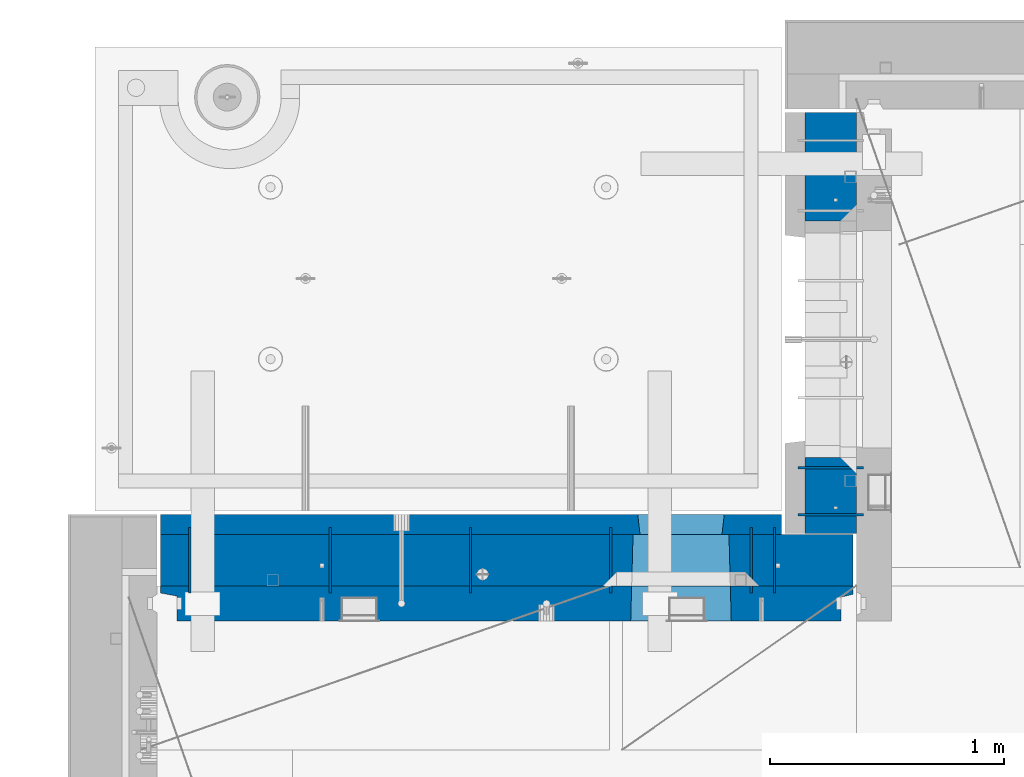
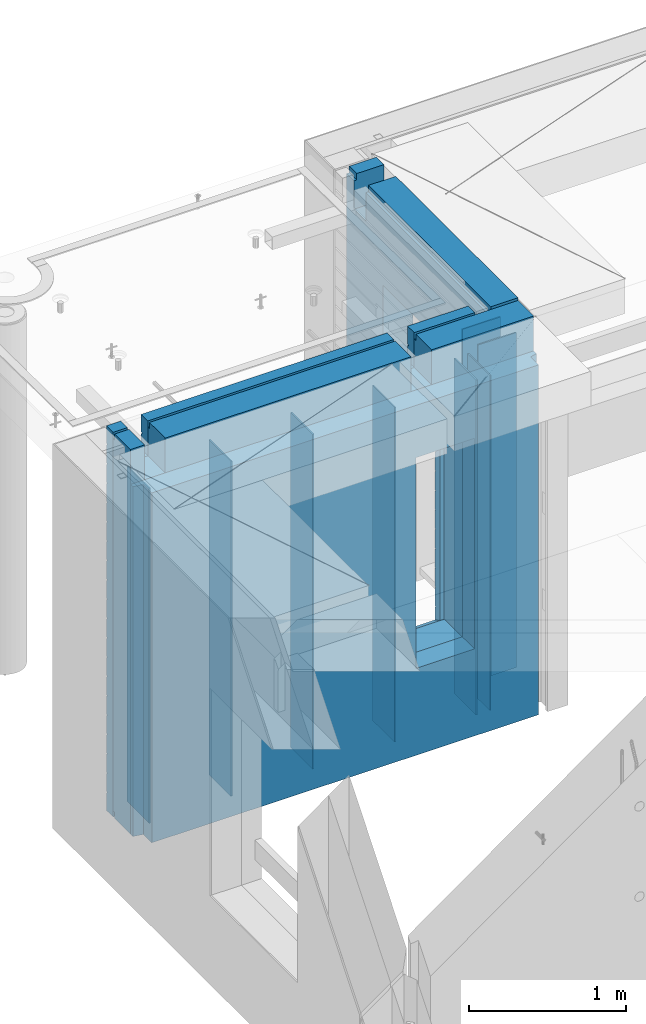
# One storey, part 235 of 349: 12 walls, 2 elements without a shape of their own.
"""IFC2X3 building model written with IfcOpenShell, lengths in millimetres."""

from ifc_helpers import new_model, si_unit, frame, origin_with_axes, place, context, subcontext, project, spatial, faceted_brep, material, type_object, element, aggregate, save


model = new_model("IFC2X3")

# Units and contexts
model_context = context("Model", 3, precision=1e-05, world=origin_with_axes())
body_context = subcontext(model_context, "Body", "Model", "MODEL_VIEW")
ifc_project = project(units=[si_unit("LENGTHUNIT", "METRE", prefix="MILLI"), si_unit("AREAUNIT", "SQUARE_METRE"), si_unit("VOLUMEUNIT", "CUBIC_METRE"), si_unit("MASSUNIT", "GRAM", prefix="KILO"), si_unit("TIMEUNIT", "SECOND"), si_unit("PLANEANGLEUNIT", "RADIAN"), si_unit("SOLIDANGLEUNIT", "STERADIAN"), si_unit("THERMODYNAMICTEMPERATUREUNIT", "DEGREE_CELSIUS"), si_unit("LUMINOUSINTENSITYUNIT", "LUMEN")], contexts=[model_context])

# Site, building, storey
site_placement = place(None, origin_with_axes())
site = spatial("IfcSite", under=ifc_project, at=site_placement, CompositionType="ELEMENT")
building_placement = place(site_placement, origin_with_axes())
building = spatial("IfcBuilding", under=site, at=building_placement, CompositionType="ELEMENT")
storey_placement = place(building_placement, origin_with_axes())
storey = spatial("IfcBuildingStorey", under=building, at=storey_placement, Name="4", CompositionType="ELEMENT", Elevation=0.0)

# Assembly, wall
assembly_1_placement = place(storey_placement, origin_with_axes())
assembly_1 = element("IfcElementAssembly", 1, at=assembly_1_placement, inside=storey, AssemblyPlace="NOTDEFINED", PredefinedType="REINFORCEMENT_UNIT")
ifc_material_1 = material(Name="Undefined")
wall_type_1 = type_object("IfcWallType", PredefinedType="NOTDEFINED")
wall_1_placement = place(assembly_1_placement, frame((11020.0, 20885.0002441406, 92115.0), z_axis=(0.0, 0.0, 1.0), x_axis=(-1.0, 3.00000001838171e-08, 0.0)))
wall_1 = element("IfcWall", 2, at=wall_1_placement, type_object=wall_type_1, material=ifc_material_1, Name="(PD)", context=body_context, shape_type="Brep", body=[
    faceted_brep([(0.0, 5.0, -1300.0), (0.0, 5.0, 1300.0), (280.0, 5.0, 1300.0), (280.0, 5.0, -1300.0), (0.0, -5.0, 1300.0), (280.0, -5.0, 1300.0), (0.0, -5.0, -1300.0), (280.0, -5.0, -1300.0)], [[[0, 1, 2, 3]], [[1, 4, 5, 2]], [[4, 6, 7, 5]], [[6, 0, 3, 7]], [[5, 7, 3, 2]], [[6, 4, 1, 0]]]),
])

assembly_2_placement = place(storey_placement, origin_with_axes())
assembly_2 = element("IfcElementAssembly", 3, at=assembly_2_placement, inside=storey, AssemblyPlace="NOTDEFINED", PredefinedType="REINFORCEMENT_UNIT")
wall_2_placement = place(assembly_2_placement, frame((10640.0002441406, 20549.9951872276, 92115.0), z_axis=(0.0, 0.0, 1.0), x_axis=(0.0, 1.0, 0.0)))
wall_2 = element("IfcWall", 4, at=wall_2_placement, type_object=wall_type_1, material=ifc_material_1, Name="(PD)", context=body_context, shape_type="Brep", body=[
    faceted_brep([(0.0, 5.0, -1300.0), (0.0, 5.0, 1300.0), (280.0, 5.0, 1300.0), (280.0, 5.0, -1300.0), (0.0, -5.0, 1300.0), (280.0, -5.0, 1300.0), (0.0, -5.0, -1300.0), (280.0, -5.0, -1300.0)], [[[0, 1, 2, 3]], [[1, 4, 5, 2]], [[4, 6, 7, 5]], [[6, 0, 3, 7]], [[5, 7, 3, 2]], [[6, 4, 1, 0]]]),
])

# Wall
wall_3_placement = place(assembly_1_placement, frame((11020.0, 21085.0002441406, 92115.0), z_axis=(0.0, 0.0, 1.0), x_axis=(-1.0, 3.00000001838171e-08, 0.0)))
wall_3 = element("IfcWall", 5, at=wall_3_placement, type_object=wall_type_1, material=ifc_material_1, Name="(PD)", context=body_context, shape_type="Brep", body=[
    faceted_brep([(0.0, 5.0, -1300.0), (0.0, 5.0, 1300.0), (280.0, 5.0, 1300.0), (280.0, 5.0, -1300.0), (0.0, -5.0, 1300.0), (280.0, -5.0, 1300.0), (0.0, -5.0, -1300.0), (280.0, -5.0, -1300.0)], [[[0, 1, 2, 3]], [[1, 4, 5, 2]], [[4, 6, 7, 5]], [[6, 0, 3, 7]], [[5, 7, 3, 2]], [[6, 4, 1, 0]]]),
])

wall_4_placement = place(assembly_2_placement, frame((8140.00024414063, 20549.9951872276, 92115.0), z_axis=(0.0, 0.0, 1.0), x_axis=(0.0, 1.0, 0.0)))
wall_4 = element("IfcWall", 6, at=wall_4_placement, type_object=wall_type_1, material=ifc_material_1, Name="(PD)", context=body_context, shape_type="Brep", body=[
    faceted_brep([(0.0, 5.0, -1300.0), (0.0, 5.0, 1300.0), (280.0, 5.0, 1300.0), (280.0, 5.0, -1300.0), (0.0, -5.0, 1300.0), (280.0, -5.0, 1300.0), (0.0, -5.0, -1300.0), (280.0, -5.0, -1300.0)], [[[0, 1, 2, 3]], [[1, 4, 5, 2]], [[4, 6, 7, 5]], [[6, 0, 3, 7]], [[5, 7, 3, 2]], [[6, 4, 1, 0]]]),
])

wall_5_placement = place(assembly_2_placement, frame((8740.00024414063, 20549.9951872276, 92115.0), z_axis=(0.0, 0.0, 1.0), x_axis=(0.0, 1.0, 0.0)))
wall_5 = element("IfcWall", 7, at=wall_5_placement, type_object=wall_type_1, material=ifc_material_1, Name="(PD)", context=body_context, shape_type="Brep", body=[
    faceted_brep([(0.0, 5.0, -1300.0), (0.0, 5.0, 1300.0), (280.0, 5.0, 1300.0), (280.0, 5.0, -1300.0), (0.0, -5.0, 1300.0), (280.0, -5.0, 1300.0), (0.0, -5.0, -1300.0), (280.0, -5.0, -1300.0)], [[[0, 1, 2, 3]], [[1, 4, 5, 2]], [[4, 6, 7, 5]], [[6, 0, 3, 7]], [[5, 7, 3, 2]], [[6, 4, 1, 0]]]),
])

wall_6_placement = place(assembly_2_placement, frame((9340.00024414063, 20549.9951872276, 92115.0), z_axis=(0.0, 0.0, 1.0), x_axis=(0.0, 1.0, 0.0)))
wall_6 = element("IfcWall", 8, at=wall_6_placement, type_object=wall_type_1, material=ifc_material_1, Name="(PD)", context=body_context, shape_type="Brep", body=[
    faceted_brep([(0.0, 5.0, -1300.0), (0.0, 5.0, 1300.0), (280.0, 5.0, 1300.0), (280.0, 5.0, -1300.0), (0.0, -5.0, 1300.0), (280.0, -5.0, 1300.0), (0.0, -5.0, -1300.0), (280.0, -5.0, -1300.0)], [[[0, 1, 2, 3]], [[1, 4, 5, 2]], [[4, 6, 7, 5]], [[6, 0, 3, 7]], [[5, 7, 3, 2]], [[6, 4, 1, 0]]]),
])

wall_7_placement = place(assembly_2_placement, frame((9940.00024414063, 20549.9951872276, 92115.0), z_axis=(0.0, 0.0, 1.0), x_axis=(0.0, 1.0, 0.0)))
wall_7 = element("IfcWall", 9, at=wall_7_placement, type_object=wall_type_1, material=ifc_material_1, Name="(PD)", context=body_context, shape_type="Brep", body=[
    faceted_brep([(0.0, 5.0, -1300.0), (0.0, 5.0, 1300.0), (280.0, 5.0, 1300.0), (280.0, 5.0, -1300.0), (0.0, -5.0, 1300.0), (280.0, -5.0, 1300.0), (0.0, -5.0, -1300.0), (280.0, -5.0, -1300.0)], [[[0, 1, 2, 3]], [[1, 4, 5, 2]], [[4, 6, 7, 5]], [[6, 0, 3, 7]], [[5, 7, 3, 2]], [[6, 4, 1, 0]]]),
])

wall_8_placement = place(assembly_2_placement, frame((10540.0002441406, 20549.9951872276, 92115.0), z_axis=(0.0, 0.0, 1.0), x_axis=(0.0, 1.0, 0.0)))
wall_8 = element("IfcWall", 10, at=wall_8_placement, type_object=wall_type_1, material=ifc_material_1, Name="(PD)", context=body_context, shape_type="Brep", body=[
    faceted_brep([(0.0, 5.0, -1300.0), (0.0, 5.0, 1300.0), (280.0, 5.0, 1300.0), (280.0, 5.0, -1300.0), (0.0, -5.0, 1300.0), (280.0, -5.0, 1300.0), (0.0, -5.0, -1300.0), (280.0, -5.0, -1300.0)], [[[0, 1, 2, 3]], [[1, 4, 5, 2]], [[4, 6, 7, 5]], [[6, 0, 3, 7]], [[5, 7, 3, 2]], [[6, 4, 1, 0]]]),
])

ifc_material_2 = material(Name="COS5gt")
wall_type_2 = type_object("IfcWallType", PredefinedType="NOTDEFINED")
wall_9_placement = place(assembly_1_placement, frame((10880.0, 20805.0, 92247.5), z_axis=(0.0, 0.0, 1.0), x_axis=(0.0, 1.0, 0.0)))
wall_9 = element("IfcWall", 11, at=wall_9_placement, type_object=wall_type_2, material=ifc_material_2, context=body_context, shape_type="Brep", body=[
    faceted_brep([(1800.0, -110.0, 1492.5), (1800.0, 90.0, 1492.5), (1705.0, 90.0, 1492.5), (1705.0, -110.0, 1492.5), (1800.0, 90.0, 1442.5), (1800.0, 110.0, 1442.5), (1705.0, 110.0, 1442.5), (1705.0, 90.0, 1442.5), (0.0, 110.0, 1442.5), (0.0, 90.0, 1442.5), (1555.0, 90.0, 1442.5), (1555.0, 110.0, 1442.5), (0.0, -110.0, -1492.5), (0.0, 90.0, -1492.5), (325.000271651108, 90.0, -1492.5), (325.000271651108, -110.0, -1492.5), (0.0, 90.0, -1442.5), (325.000271651108, 90.0, -1442.5), (0.0, -110.0, 1492.5), (0.0, 90.0, 1492.5), (0.0, 110.0, -1442.5), (325.000271651108, 110.0, -1442.5), (325.000271651108, 110.0, 857.5), (325.000271651108, -110.0, 857.5), (1335.00027165111, 110.0, 857.5), (1335.00027165111, -110.0, 857.5), (1555.0, 110.0, 1222.5), (1705.0, 110.0, 1222.5), (1800.0, 110.0, -1442.5), (1335.00027165111, 110.0, -1442.5), (1800.0, 90.0, -1442.5), (1800.0, 90.0, -1492.5), (1335.00027165111, 90.0, -1492.5), (1335.00027165111, 90.0, -1442.5), (1800.0, -110.0, -1492.5), (1335.00027165111, -110.0, -1492.5), (1705.0, -110.0, 1222.5), (1555.0, -110.0, 1222.5), (1555.0, -110.0, 1492.5), (1555.0, 90.0, 1492.5)], [[[0, 1, 2, 3]], [[4, 5, 6, 7]], [[8, 9, 10, 11]], [[12, 13, 14, 15]], [[13, 16, 17, 14]], [[13, 12, 18, 19, 9, 8, 20, 16]], [[16, 20, 21, 17]], [[15, 14, 17, 21, 22, 23]], [[23, 22, 24, 25]], [[21, 20, 8, 11, 26, 27, 6, 5, 28, 29, 24, 22]], [[30, 31, 32, 33]], [[28, 30, 33, 29]], [[5, 4, 1, 0, 34, 31, 30, 28]], [[31, 34, 35, 32]], [[25, 24, 29, 33, 32, 35]], [[34, 0, 3, 36, 37, 38, 18, 12, 15, 23, 25, 35]], [[19, 18, 38, 39]], [[9, 19, 39, 10]], [[38, 37, 26, 11, 10, 39]], [[36, 27, 26, 37]], [[3, 2, 7, 6, 27, 36]], [[1, 4, 7, 2]]]),
])

aggregate(assembly_1, [wall_1, wall_3, wall_9])

wall_10_placement = place(assembly_2_placement, frame((8000.0, 20689.9951872276, 92247.5), z_axis=(0.0, 0.0, 1.0), x_axis=(1.0, 0.0, 0.0)))
wall_10 = element("IfcWall", 12, at=wall_10_placement, type_object=wall_type_2, material=ifc_material_2, context=body_context, shape_type="Brep", body=[
    faceted_brep([(2075.0, 110.0, 1442.5), (2075.0, 90.0, 1442.5), (2075.0, 90.0, 1492.5), (2075.0, -110.0, 1492.5), (2075.0, -110.000000000004, 1222.5), (2075.0, 109.999999999996, 1222.5), (2225.0, -110.000000000004, 1222.5), (2225.0, 109.999999999996, 1222.5), (2225.0, 110.0, 1442.5), (2225.0, -110.0, 1492.5), (2225.0, 90.0, 1492.5), (2225.0, 90.0, 1442.5), (2975.0, 90.0, -1492.5), (15.0, 90.0, -1492.5), (15.0, 90.0, -1442.5), (2975.0, 90.0, -1442.5), (2975.0, -110.0, -1492.5), (15.0, -110.0, -1492.5), (15.0, 90.0, 1442.5), (15.0, 90.0, 1492.5), (119.999999999998, 90.0, 1492.5), (119.999999999998, 90.0, 1442.5), (15.0, -110.0, 1492.5), (119.999999999998, -110.0, 1492.5), (269.999999999998, 110.0, 1442.5), (269.999999999998, 90.0, 1442.5), (269.999999999998, 90.0, 1492.5), (269.999999999998, -110.0, 1492.5), (269.999999999998, 110.0, 1222.5), (269.999999999998, -110.0, 1222.5), (119.999999999998, 110.0, 1222.5), (119.999999999998, -110.0, 1222.5), (119.999999999998, 110.0, 1442.5), (15.0, 110.0, 1442.5), (15.0, 110.0, -1442.5), (2975.0, 110.0, -1442.5), (2975.0, 110.0, 1442.5), (2975.0, 90.0, 1442.5), (2975.0, 90.0, 1492.5), (2975.0, -110.0, 1492.5), (2029.05276420954, -110.0, -813.445945945947), (2029.05276420954, -110.0, 813.445945945947), (2450.94465610143, -110.0, 813.445945945947), (2450.94465610143, -110.0, -813.445945945947), (2034.99871015549, 110.0, -802.5), (2034.99871015549, 110.0, 807.5), (2034.99871015549, 110.0, -807.5), (2444.99871015549, 110.0, -807.5), (2414.99871015549, 110.0, -807.5), (2064.99871015549, 110.0, -807.5), (2444.99871015549, 110.0, 807.5), (2444.99871015549, 110.0, -802.5)], [[[0, 1, 2, 3, 4, 5]], [[5, 4, 6, 7]], [[8, 7, 6, 9, 10, 11]], [[12, 13, 14, 15]], [[16, 17, 13, 12]], [[18, 19, 20, 21]], [[19, 22, 23, 20]], [[24, 25, 1, 0]], [[26, 27, 3, 2]], [[25, 26, 2, 1]], [[24, 28, 29, 27, 26, 25]], [[30, 31, 29, 28]], [[32, 21, 20, 23, 31, 30]], [[33, 18, 21, 32]], [[13, 17, 22, 19, 18, 33, 34, 14]], [[35, 15, 14, 34]], [[36, 37, 38, 39, 16, 12, 15, 35]], [[37, 36, 8, 11]], [[38, 37, 11, 10]], [[39, 38, 10, 9]], [[4, 3, 27, 29, 31, 23, 22, 17, 16, 39, 9, 6], [40, 41, 42, 43]], [[44, 45, 41, 40, 46]], [[43, 47, 48, 49, 46, 40]], [[42, 50, 51, 47, 43]], [[41, 45, 50, 42]], [[36, 35, 34, 33, 32, 30, 28, 24, 0, 5, 7, 8], [44, 46, 49, 48, 47, 51, 50, 45]]]),
])

ifc_material_3 = material(Name="CONCRETE/C30/37")
wall_type_3 = type_object("IfcWallType", PredefinedType="NOTDEFINED")
wall_11_placement = place(assembly_2_placement, frame((8000.0, 20842.4951872276, 92247.5), z_axis=(0.0, 0.0, 1.0), x_axis=(1.0, 0.0, 0.0)))
wall_11 = element("IfcWall", 13, at=wall_11_placement, type_object=wall_type_3, material=ifc_material_3, context=body_context, shape_type="Brep", body=[
    faceted_brep([(2075.0, 42.5, 1492.5), (2075.0, -42.5, 1492.5), (2075.0, -42.5000000000036, 1222.5), (2075.0, 42.4999994593163, 1222.5), (2075.0, 42.4999996925035, 1342.99999994476), (2075.0, 32.4999992506928, 1344.9999999992), (2075.0, 32.4999991126933, 1355.00000040043), (2075.0, 42.4999994127757, 1356.99999988925), (2225.0, -42.5000000000036, 1222.5), (2225.0, 42.4999994264763, 1222.5), (2225.0, 42.5, 1492.5), (2225.0, 42.4999993700148, 1356.99999988925), (2225.0, 32.4999991126933, 1355.00000040043), (2225.0, 32.4999992506928, 1344.9999999992), (2225.0, 42.4999996701117, 1342.99999994476), (2225.0, -42.5, 1492.5), (2054.99871015549, 42.5, -857.5), (2064.99871015549, -42.5, -807.5), (2414.99871015549, -42.5, -807.5), (2424.99871015549, 42.5, -857.5), (15.0, 42.5, -757.000000055239), (15.0, 32.4999992506928, -755.0000000008), (2056.17518083188, 32.4999992506928, -755.0000000008), (2054.99871015549, 42.4999994516256, -757.000000055239), (15.0, 32.4999991126933, -744.999999599575), (2056.17518084811, 32.4999991126933, -744.999999599575), (15.0, 42.5, -743.000000110755), (2054.99871015549, 42.4999994184764, -743.000000110755), (15.0, 42.5, -607.000000055239), (2054.99871015549, 42.4999994538521, -607.000000055239), (15.0, 32.4999992506928, -605.0000000008), (2056.17518083188, 32.4999992506928, -605.0000000008), (15.0, 32.4999991126933, -594.999999599575), (2056.17518084811, 32.4999991126933, -594.999999599575), (15.0, 42.5, -593.000000110755), (2054.99871015549, 42.4999994184764, -593.000000110755), (15.0, 42.5, -457.000000055239), (2054.99871015549, 42.4999994563987, -457.000000055239), (15.0000000000009, 32.4999992506928, -455.0000000008), (2056.17518083188, 32.4999992506928, -455.0000000008), (15.0000000000009, 32.4999991126933, -444.999999599575), (2056.17518084811, 32.4999991126933, -444.999999599575), (15.0, 42.5, -443.000000110755), (2054.99871015549, 42.4999994184764, -443.000000110755), (15.0, 42.5, -307.000000055239), (2054.99871015549, 42.4999994593381, -307.000000055239), (15.0, 32.4999992506928, -305.0000000008), (2056.17518083188, 32.4999992506928, -305.0000000008), (15.0, 32.4999991126933, -294.999999599575), (2056.17518084811, 32.4999991126933, -294.999999599575), (15.0, 42.5, -293.000000110755), (2054.99871015549, 42.4999994184764, -293.000000110755), (15.0, 42.5, -157.000000055239), (2054.99871015549, 42.4999994627688, -157.000000055239), (15.0000000000009, 32.4999992506928, -155.0000000008), (2056.17518083188, 32.4999992506928, -155.0000000008), (15.0000000000009, 32.4999991126933, -144.999999599575), (2056.17518084811, 32.4999991126933, -144.999999599575), (15.0, 42.5, -143.000000110755), (2054.99871015549, 42.4999994184764, -143.000000110755), (15.0, 42.5, -7.00000005523907), (2054.99871015549, 42.4999994668287, -7.00000005523907), (14.9999999999991, 32.4999992506928, -5.00000000080036), (2056.17518083188, 32.4999992506928, -5.00000000080036), (14.9999999999991, 32.4999991126933, 5.00000040042505), (2056.17518084811, 32.4999991126933, 5.00000040042505), (15.0, 42.5, 6.99999988924537), (2054.99871015549, 42.4999994184764, 6.99999988924537), (15.0, 42.5, 142.999999944761), (2054.99871015549, 42.4999994717145, 142.999999944761), (15.0000000000009, 32.4999992506928, 144.9999999992), (2056.17518083188, 32.4999992506928, 144.9999999992), (15.0000000000009, 32.4999991126933, 155.000000400425), (2056.17518084811, 32.4999991126933, 155.000000400425), (15.0, 42.5, 156.999999889245), (2054.99871015549, 42.4999994184764, 156.999999889245), (15.0, 42.5, 292.999999944761), (2054.99871015549, 42.4999994776954, 292.999999944761), (15.0, 32.4999992506928, 294.9999999992), (2056.17518083188, 32.4999992506928, 294.9999999992), (15.0, 32.4999991126933, 305.000000400425), (2056.17518084811, 32.4999991126933, 305.000000400425), (15.0, 42.5, 306.999999889245), (2054.99871015549, 42.4999994184764, 306.999999889245), (15.0, 42.5, 442.999999944761), (2054.99871015549, 42.499999485186, 442.999999944761), (15.0, 32.4999992506928, 444.9999999992), (2056.17518083188, 32.4999992506928, 444.9999999992), (15.0, 32.4999991126933, 455.000000400425), (2056.17518084811, 32.4999991126933, 455.000000400425), (15.0, 42.5, 456.999999889245), (2054.99871015549, 42.4999994184764, 456.999999889245), (15.0, 42.5, 592.999999944761), (2054.99871015549, 42.4999994948485, 592.999999944761), (15.0, 32.4999992506928, 594.9999999992), (2056.17518083188, 32.4999992506928, 594.9999999992), (15.0, 32.4999991126933, 605.000000400425), (2056.17518084811, 32.4999991126933, 605.000000400425), (15.0, 42.5, 606.999999889245), (2054.99871015549, 42.4999994184764, 606.999999889245), (15.0, 42.5, 742.999999944761), (2054.99871015549, 42.4999995077887, 742.999999944761), (15.0, 32.4999992506928, 744.9999999992), (2056.17518083188, 32.4999992506928, 744.9999999992), (15.0, 32.4999991126933, 755.000000400425), (2056.17518084811, 32.4999991126933, 755.000000400425), (15.0, 42.5, 756.999999889245), (2054.99871015549, 42.4999994184764, 756.999999889245), (2670.0, 32.4999992506928, 1194.9999999992), (15.0000000000009, 32.4999992506928, 1194.9999999992), (15.0000000000009, 32.4999991126933, 1205.00000040043), (2670.0, 32.4999991126933, 1205.00000040043), (2670.0, 42.4999994795107, 1192.99999994476), (15.0, 42.5, 1192.99999994476), (2670.0, 42.4999992431622, 1056.99999988925), (15.0, 42.5, 1056.99999988925), (2670.0, 32.4999991126933, 1055.00000040043), (15.0, 32.4999991126933, 1055.00000040043), (2670.0, 32.4999992506928, 1044.9999999992), (15.0, 32.4999992506928, 1044.9999999992), (2670.0, 42.4999994189602, 1042.99999994476), (15.0, 42.5, 1042.99999994476), (2670.0, 42.4999992431622, 906.999999889245), (15.0, 42.5, 906.999999889245), (2670.0, 32.4999991126933, 905.000000400425), (15.0, 32.4999991126933, 905.000000400425), (2670.0, 32.4999992506928, 894.9999999992), (15.0, 32.4999992506928, 894.9999999992), (2670.0, 42.4999993831079, 892.999999944761), (15.0, 42.5, 892.999999944761), (2670.0, 32.4999992506928, -755.0000000008), (2670.0, 42.4999992863086, -757.000000055239), (2424.99871015549, 42.4999993521669, -757.000000055239), (2423.8222394791, 32.4999992506928, -755.0000000008), (2670.0, 32.4999991126933, -744.999999599575), (2423.82223946286, 32.4999991126933, -744.999999599575), (2670.0, 42.4999992431622, -743.000000110755), (2424.99871015549, 42.4999993130041, -743.000000110755), (2670.0, 42.4999992892044, -607.000000055239), (2424.99871015549, 42.4999993547972, -607.000000055239), (2670.0, 32.4999992506928, -605.0000000008), (2423.8222394791, 32.4999992506928, -605.0000000008), (2670.0, 32.4999991126933, -594.999999599575), (2423.82223946286, 32.4999991126933, -594.999999599575), (2670.0, 42.4999992431622, -593.000000110755), (2424.99871015549, 42.4999993130041, -593.000000110755), (2670.0, 42.4999992925186, -457.000000055239), (2424.99871015549, 42.4999993578058, -457.000000055239), (2670.0, 32.4999992506928, -455.0000000008), (2423.8222394791, 32.4999992506928, -455.0000000008), (2670.0, 32.4999991126933, -444.999999599575), (2423.82223946286, 32.4999991126933, -444.999999599575), (2670.0, 42.4999992431622, -443.000000110755), (2424.99871015549, 42.4999993130041, -443.000000110755), (2670.0, 42.4999992963421, -307.000000055239), (2424.99871015549, 42.4999993612764, -307.000000055239), (2670.0, 32.4999992506928, -305.0000000008), (2423.8222394791, 32.4999992506928, -305.0000000008), (2670.0, 32.4999991126933, -294.999999599575), (2423.82223946286, 32.4999991126933, -294.999999599575), (2670.0, 42.4999992431622, -293.000000110755), (2424.99871015549, 42.4999993130041, -293.000000110755), (2670.0, 42.4999993008096, -157.000000055239), (2424.99871015549, 42.4999993653291, -157.000000055239), (2670.0, 32.4999992506928, -155.0000000008), (2423.8222394791, 32.4999992506928, -155.0000000008), (2670.0, 32.4999991126933, -144.999999599575), (2423.82223946286, 32.4999991126933, -144.999999599575), (2670.0, 42.4999992431622, -143.000000110755), (2424.99871015549, 42.4999993130041, -143.000000110755), (2670.0, 42.4999993060956, -7.00000005523907), (2424.99871015549, 42.4999993701276, -7.00000005523907), (2670.0, 32.4999992506928, -5.00000000080036), (2423.8222394791, 32.4999992506928, -5.00000000080036), (2670.0, 32.4999991126933, 5.00000040042505), (2423.82223946286, 32.4999991126933, 5.00000040042505), (2670.0, 42.4999992431622, 6.99999988924537), (2424.99871015549, 42.4999993130041, 6.99999988924537), (2670.0, 42.4999993124511, 142.999999944761), (2424.99871015549, 42.4999993758975, 142.999999944761), (2670.0, 32.4999992506928, 144.9999999992), (2423.8222394791, 32.4999992506928, 144.9999999992), (2670.0, 32.4999991126933, 155.000000400425), (2423.82223946286, 32.4999991126933, 155.000000400425), (2670.0, 42.4999992431622, 156.999999889245), (2424.99871015549, 42.4999993130041, 156.999999889245), (2670.0, 42.4999993202327, 292.999999944761), (2424.99871015549, 42.4999993829624, 292.999999944761), (2670.0, 32.4999992506928, 294.9999999992), (2423.8222394791, 32.4999992506928, 294.9999999992), (2670.0, 32.4999991126933, 305.000000400425), (2423.82223946286, 32.4999991126933, 305.000000400425), (2670.0, 42.4999992431622, 306.999999889245), (2424.99871015549, 42.4999993130041, 306.999999889245), (2670.0, 42.4999993299862, 442.999999944761), (2424.99871015549, 42.4999993918136, 442.999999944761), (2670.0, 32.4999992506928, 444.9999999992), (2423.8222394791, 32.4999992506928, 444.9999999992), (2670.0, 32.4999991126933, 455.000000400425), (2423.82223946286, 32.4999991126933, 455.000000400425), (2670.0, 42.4999992431622, 456.999999889245), (2424.99871015549, 42.4999993130041, 456.999999889245), (2670.0, 42.4999993425627, 592.999999944761), (2424.99871015549, 42.4999994032296, 592.999999944761), (2670.0, 32.4999992506928, 594.9999999992), (2423.8222394791, 32.4999992506928, 594.9999999992), (2670.0, 32.4999991126933, 605.000000400425), (2423.82223946286, 32.4999991126933, 605.000000400425), (2670.0, 42.4999992431622, 606.999999889245), (2424.99871015549, 42.4999993130041, 606.999999889245), (2670.0, 42.4999993594029, 742.999999944761), (2424.99871015549, 42.4999994185164, 742.999999944761), (2670.0, 32.4999992506928, 744.9999999992), (2423.8222394791, 32.4999992506928, 744.9999999992), (2670.0, 32.4999991126933, 755.000000400425), (2423.82223946286, 32.4999991126933, 755.000000400425), (2670.0, 42.4999992431622, 756.999999889245), (2424.99871015549, 42.4999993130041, 756.999999889245), (2064.99871015549, 42.5, 782.5), (2054.99871015549, 42.5, 782.5), (2424.99871015549, 42.5, 782.5), (2414.99871015549, 42.5, 782.5), (2064.99871015549, -42.5, 782.5), (2064.99871015549, -42.5, 787.5), (2414.99871015549, -42.5, 787.5), (2414.99871015549, -42.5, 782.5), (2670.0, 42.4999992431622, -893.000000110755), (15.0, 42.5, -893.000000110755), (2670.0, 32.4999991126933, -894.999999599575), (15.0000000000009, 32.4999991126933, -894.999999599575), (2670.0, 32.4999992506928, -905.0000000008), (15.0000000000009, 32.4999992506928, -905.0000000008), (2670.0, 42.4999992837584, -907.000000055239), (15.0, 42.5, -907.000000055239), (2670.0, 42.4999992431622, -1043.00000011075), (15.0, 42.5, -1043.00000011075), (2670.0, 32.4999991126933, -1044.99999959957), (15.0, 32.4999991126933, -1044.99999959957), (2670.0, 32.4999992506928, -1055.0000000008), (15.0, 32.4999992506928, -1055.0000000008), (2670.0, 42.4999992814919, -1057.00000005524), (15.0, 42.5, -1057.00000005524), (2670.0, 42.4999992431622, -1193.00000011075), (15.0, 42.5, -1193.00000011075), (2670.0, 32.4999991126933, -1194.99999959957), (15.0, 32.4999991126933, -1194.99999959957), (2670.0, 32.4999992506928, -1205.0000000008), (15.0, 32.4999992506928, -1205.0000000008), (2670.0, 42.4999992794619, -1207.00000005524), (15.0, 42.5, -1207.00000005524), (2670.0, 42.4999992431622, -1343.00000011075), (15.0, 42.5, -1343.00000011075), (2670.0, 32.4999991126933, -1344.99999959957), (15.0, 32.4999991126933, -1344.99999959957), (2670.0, 32.4999992506928, -1355.0000000008), (15.0, 32.4999992506928, -1355.0000000008), (2670.0, 42.5, -1357.00000005524), (15.0, 42.5, -1357.00000005524), (2670.0, 42.5, -1492.5), (15.0, 42.5, -1492.5), (15.0, -42.5, -1492.5), (2670.0, -42.5, -1492.5), (15.0, 42.5, 1356.99999988925), (15.0, 42.5, 1492.5), (119.999999999998, 42.5, 1492.5), (119.999999999998, 42.4999999700703, 1356.99999988925), (15.0, -42.5, 1492.5), (119.999999999998, -42.5, 1492.5), (269.999999999998, 42.5, 1492.5), (269.999999999998, 42.4999999273095, 1356.99999988925), (269.999999999998, 32.4999991126933, 1355.00000040043), (269.999999999998, 32.4999992506928, 1344.9999999992), (269.999999999998, 42.4999999619358, 1342.99999994476), (269.999999999998, 42.4999998750354, 1222.5), (269.999999999998, -42.5, 1222.5), (269.999999999998, -42.5, 1492.5), (119.999999999998, 42.4999999076099, 1222.5), (119.999999999998, -42.5, 1222.5), (15.0, 42.5, 1342.99999994476), (15.0, 32.4999992506928, 1344.9999999992), (119.999999999998, 32.4999992506928, 1344.9999999992), (119.999999999998, 42.4999999843276, 1342.99999994476), (15.0, 32.4999991126933, 1355.00000040043), (119.999999999998, 32.4999991126933, 1355.00000040043), (15.0, 42.5, 1206.99999988925), (2670.0, 42.4999992431622, 1206.99999988925), (2670.0, 42.5, 1492.5), (2670.0, -42.5, 1492.5), (2670.0, 42.4999996036859, 1342.99999994476), (2670.0, 32.4999992506928, 1344.9999999992), (2670.0, 32.4999991126933, 1355.00000040043), (2670.0, 42.4999992431622, 1356.99999988925)], [[[0, 1, 2, 3, 4, 5, 6, 7]], [[3, 2, 8, 9]], [[10, 11, 12, 13, 14, 9, 8, 15]], [[16, 17, 18, 19]], [[20, 21, 22, 23]], [[21, 24, 25, 22]], [[24, 26, 27, 25]], [[26, 28, 29, 27]], [[28, 30, 31, 29]], [[30, 32, 33, 31]], [[32, 34, 35, 33]], [[34, 36, 37, 35]], [[36, 38, 39, 37]], [[38, 40, 41, 39]], [[40, 42, 43, 41]], [[42, 44, 45, 43]], [[44, 46, 47, 45]], [[46, 48, 49, 47]], [[48, 50, 51, 49]], [[50, 52, 53, 51]], [[52, 54, 55, 53]], [[54, 56, 57, 55]], [[56, 58, 59, 57]], [[58, 60, 61, 59]], [[60, 62, 63, 61]], [[62, 64, 65, 63]], [[64, 66, 67, 65]], [[66, 68, 69, 67]], [[68, 70, 71, 69]], [[70, 72, 73, 71]], [[72, 74, 75, 73]], [[74, 76, 77, 75]], [[76, 78, 79, 77]], [[78, 80, 81, 79]], [[80, 82, 83, 81]], [[82, 84, 85, 83]], [[84, 86, 87, 85]], [[86, 88, 89, 87]], [[88, 90, 91, 89]], [[90, 92, 93, 91]], [[92, 94, 95, 93]], [[94, 96, 97, 95]], [[96, 98, 99, 97]], [[98, 100, 101, 99]], [[100, 102, 103, 101]], [[102, 104, 105, 103]], [[104, 106, 107, 105]], [[108, 109, 110, 111]], [[112, 113, 109, 108]], [[114, 115, 113, 112]], [[114, 116, 117, 115]], [[118, 119, 117, 116]], [[120, 121, 119, 118]], [[122, 123, 121, 120]], [[122, 124, 125, 123]], [[126, 127, 125, 124]], [[128, 129, 127, 126]], [[130, 131, 132, 133]], [[134, 130, 133, 135]], [[136, 134, 135, 137]], [[138, 136, 137, 139]], [[140, 138, 139, 141]], [[142, 140, 141, 143]], [[144, 142, 143, 145]], [[146, 144, 145, 147]], [[148, 146, 147, 149]], [[150, 148, 149, 151]], [[152, 150, 151, 153]], [[154, 152, 153, 155]], [[156, 154, 155, 157]], [[158, 156, 157, 159]], [[160, 158, 159, 161]], [[162, 160, 161, 163]], [[164, 162, 163, 165]], [[166, 164, 165, 167]], [[168, 166, 167, 169]], [[170, 168, 169, 171]], [[172, 170, 171, 173]], [[174, 172, 173, 175]], [[176, 174, 175, 177]], [[178, 176, 177, 179]], [[180, 178, 179, 181]], [[182, 180, 181, 183]], [[184, 182, 183, 185]], [[186, 184, 185, 187]], [[188, 186, 187, 189]], [[190, 188, 189, 191]], [[192, 190, 191, 193]], [[194, 192, 193, 195]], [[196, 194, 195, 197]], [[198, 196, 197, 199]], [[200, 198, 199, 201]], [[202, 200, 201, 203]], [[204, 202, 203, 205]], [[206, 204, 205, 207]], [[208, 206, 207, 209]], [[210, 208, 209, 211]], [[212, 210, 211, 213]], [[214, 212, 213, 215]], [[216, 214, 215, 217]], [[218, 219, 107, 106, 129, 128, 216, 217, 220, 221]], [[222, 17, 16, 23, 22, 25, 27, 29, 31, 33, 35, 37, 39, 41, 43, 45, 47, 49, 51, 53, 55, 57, 59, 61, 63, 65, 67, 69, 71, 73, 75, 77, 79, 81, 83, 85, 87, 89, 91, 93, 95, 97, 99, 101, 103, 105, 107, 219, 223]], [[218, 221, 220, 224, 223, 219]], [[217, 215, 213, 211, 209, 207, 205, 203, 201, 199, 197, 195, 193, 191, 189, 187, 185, 183, 181, 179, 177, 175, 173, 171, 169, 167, 165, 163, 161, 159, 157, 155, 153, 151, 149, 147, 145, 143, 141, 139, 137, 135, 133, 132, 19, 18, 225, 224, 220]], [[131, 226, 227, 20, 23, 16, 19, 132]], [[226, 228, 229, 227]], [[230, 231, 229, 228]], [[232, 233, 231, 230]], [[234, 235, 233, 232]], [[234, 236, 237, 235]], [[238, 239, 237, 236]], [[240, 241, 239, 238]], [[242, 243, 241, 240]], [[242, 244, 245, 243]], [[246, 247, 245, 244]], [[248, 249, 247, 246]], [[250, 251, 249, 248]], [[250, 252, 253, 251]], [[254, 255, 253, 252]], [[256, 257, 255, 254]], [[258, 259, 257, 256]], [[260, 259, 258, 261]], [[262, 263, 264, 265]], [[263, 266, 267, 264]], [[268, 269, 270, 271, 272, 273, 274, 275]], [[276, 277, 274, 273]], [[278, 279, 280, 281]], [[279, 282, 283, 280]], [[264, 267, 277, 276, 281, 280, 283, 265]], [[282, 262, 265, 283]], [[279, 278, 284, 110, 109, 113, 115, 117, 119, 121, 123, 125, 127, 129, 106, 104, 102, 100, 98, 96, 94, 92, 90, 88, 86, 84, 82, 80, 78, 76, 74, 72, 70, 68, 66, 64, 62, 60, 58, 56, 54, 52, 50, 48, 46, 44, 42, 40, 38, 36, 34, 32, 30, 28, 26, 24, 21, 20, 227, 229, 231, 233, 235, 237, 239, 241, 243, 245, 247, 249, 251, 253, 255, 257, 259, 260, 266, 263, 262, 282]], [[285, 111, 110, 284]], [[286, 287, 261, 258, 256, 254, 252, 250, 248, 246, 244, 242, 240, 238, 236, 234, 232, 230, 228, 226, 131, 130, 134, 136, 138, 140, 142, 144, 146, 148, 150, 152, 154, 156, 158, 160, 162, 164, 166, 168, 170, 172, 174, 176, 178, 180, 182, 184, 186, 188, 190, 192, 194, 196, 198, 200, 202, 204, 206, 208, 210, 212, 214, 216, 128, 126, 124, 122, 120, 118, 116, 114, 112, 108, 111, 285, 288, 289, 290, 291]], [[287, 286, 10, 15]], [[2, 1, 275, 274, 277, 267, 266, 260, 261, 287, 15, 8], [18, 17, 222, 223, 224, 225]], [[268, 275, 1, 0]], [[269, 268, 0, 7]], [[270, 269, 7, 6]], [[271, 270, 6, 5]], [[272, 271, 5, 4]], [[288, 285, 284, 278, 281, 276, 273, 272, 4, 3, 9, 14]], [[289, 288, 14, 13]], [[290, 289, 13, 12]], [[291, 290, 12, 11]], [[286, 291, 11, 10]]]),
])

ifc_material_4 = material(Name="CONCRETE/C25/30")
wall_type_4 = type_object("IfcWallType", PredefinedType="NOTDEFINED")
wall_12_placement = place(assembly_2_placement, frame((8000.0, 20504.9951872276, 92112.5), z_axis=(0.0, 0.0, 1.0), x_axis=(1.0, 0.0, 0.0)))
wall_12 = element("IfcWall", 14, at=wall_12_placement, type_object=wall_type_4, material=ifc_material_4, context=body_context, shape_type="Brep", body=[
    faceted_brep([(2925.0, -75.0, 1357.5), (2925.0, -75.0, -1357.5), (2925.0, 27.0, -1357.5), (2925.0, 27.0, 1357.5), (2975.0, 75.0, 1357.5), (15.0, 75.0, 1357.5), (15.0, 45.0, 1357.5), (85.0, 32.0, 1357.5), (85.0, -75.0, 1357.5), (2975.0, 40.0, 1357.5), (85.0, 32.0, -1357.5), (85.0, -75.0, -1357.5), (15.0, 45.0, -1357.5), (15.0, 75.0, -1357.5), (2975.0, 75.0, -1357.5), (2975.0, 40.0, -1357.5), (2024.99871015549, -75.0, 952.5), (2029.05276420954, 75.0, 948.445945945947), (2450.94465610143, 75.0, 948.445945945947), (2454.99871015549, -75.0, 952.5), (2029.05276420954, 75.0, -678.445945945947), (2450.94465610143, 75.0, -678.445945945947), (2454.99871015549, -75.0, -682.5), (2024.99871015549, -75.0, -682.5)], [[[0, 1, 2, 3]], [[4, 5, 6, 7, 8, 0, 3, 9]], [[7, 10, 11, 8]], [[6, 12, 10, 7]], [[5, 13, 12, 6]], [[1, 11, 10, 12, 13, 14, 15, 2]], [[9, 3, 2, 15]], [[14, 4, 9, 15]], [[16, 17, 18, 19]], [[13, 5, 4, 14], [20, 21, 18, 17]], [[19, 18, 21, 22]], [[8, 11, 1, 0], [23, 16, 19, 22]], [[17, 16, 23, 20]], [[22, 21, 20, 23]]]),
])

aggregate(assembly_2, [wall_2, wall_4, wall_5, wall_6, wall_7, wall_8, wall_11, wall_10, wall_12])

save(model, "model.ifc")
